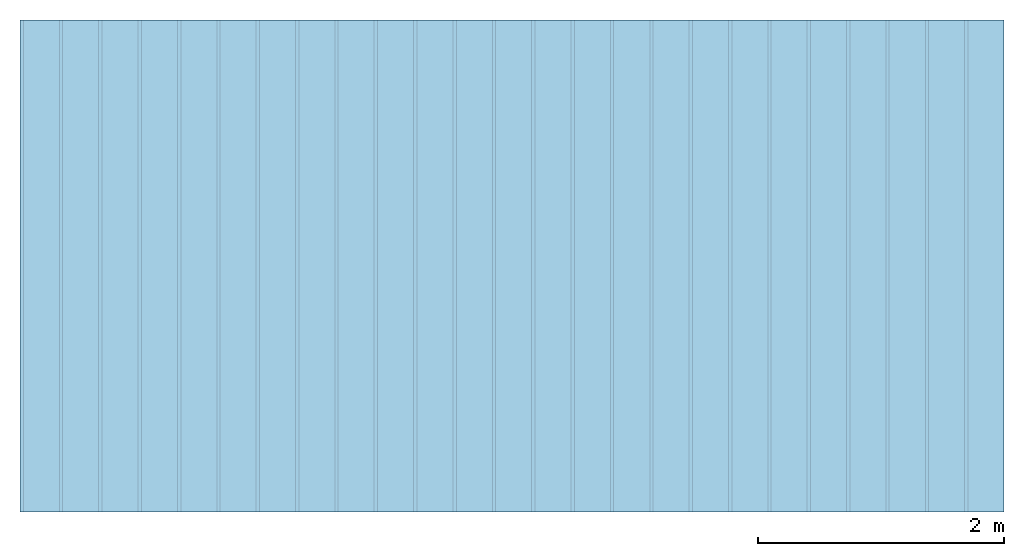
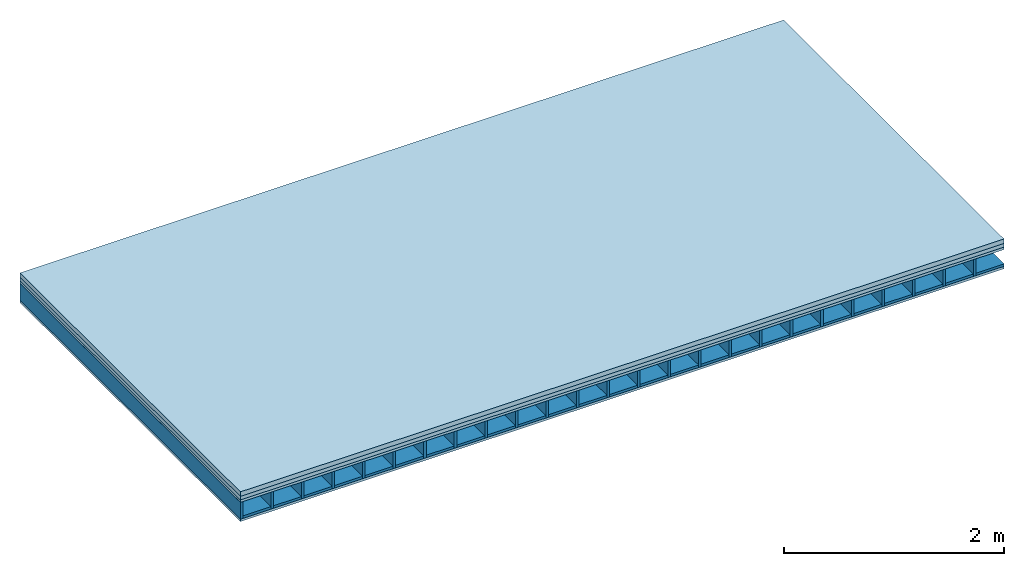
# One storey: 4 plates, 2 members, 1 element without a shape of its own.
"""IFC4 building model written with IfcOpenShell, lengths in metres."""

from ifc_helpers import new_model, si_unit, derived_unit, direction, frame, frame_2d, origin, origin_with_axes, place, context, project, spatial, rectangle, extrude, material, layer, layer_set, type_object, element, aggregate, save


model = new_model("IFC4")

# Units and contexts
plan_context = context("Plan", 3, precision=1e-05, world=origin(), true_north=direction((0.0, 1.0)))
model_context = context("Model", 3, precision=1e-05, world=origin(), true_north=direction((0.0, 1.0)))
ifc_project = project(units=[si_unit("LENGTHUNIT", "METRE"), derived_unit("SOUNDPRESSUREUNIT", [(si_unit("PRESSUREUNIT", "PASCAL", prefix="MICRO"), 0)]), si_unit("ENERGYUNIT", "JOULE", prefix="MEGA"), si_unit("MASSUNIT", "GRAM", prefix="KILO"), derived_unit("THERMALTRANSMITTANCEUNIT", [(si_unit("POWERUNIT", "WATT"), 1), (si_unit("AREAUNIT", "SQUARE_METRE"), -1), (si_unit("THERMODYNAMICTEMPERATUREUNIT", "KELVIN"), -1)]), derived_unit("AREADENSITYUNIT", [(si_unit("MASSUNIT", "GRAM", prefix="KILO"), 1), (si_unit("AREAUNIT", "SQUARE_METRE"), -1)]), derived_unit("USERDEFINED", [(si_unit("ENERGYUNIT", "JOULE", prefix="MEGA"), 1), (si_unit("AREAUNIT", "SQUARE_METRE"), -1)])], contexts=[plan_context, model_context])

# Site, building, storey
site = spatial("IfcSite", under=ifc_project)
building_placement = place(None, origin())
building = spatial("IfcBuilding", under=site, at=building_placement)
storey_placement = place(building_placement, origin())
storey = spatial("IfcBuildingStorey", under=building, at=storey_placement)

# Slab, members, plates
ifc_material_1 = material(Name="Concrete", Category="01.002")
ifc_layer_1 = layer(ifc_material_1, 0.05, Name="On-material")
ifc_material_2 = material(Name="ISOVER N 40")
ifc_layer_2 = layer(ifc_material_2, 0.04, Name="Impact sound insulation")
ifc_material_3 = material(Name="3-layer board Spruce Nova Top", Category="07.001")
ifc_layer_3 = layer(ifc_material_3, 0.027, Name="Sub-floor")
ifc_material_4 = material(Name="Rigid, of the art")
ifc_layer_4 = layer(ifc_material_4, 0.0, Name="Bond")
ifc_layer_5 = layer(None, 0.186, Name="Supporting structure")
ifc_layer_6 = layer(ifc_material_4, 0.0, Name="Bond")
ifc_layer_7 = layer(ifc_material_3, 0.027, Name="Lower layer 1")
ifc_layer_set = layer_set([ifc_layer_1, ifc_layer_2, ifc_layer_3, ifc_layer_4, ifc_layer_5, ifc_layer_6, ifc_layer_7])
slab_type = type_object("IfcSlabType", Name="A0017", PredefinedType="NOTDEFINED", material=ifc_layer_set)
slab_placement = place(None, frame((0.0, 0.0, 0.0), z_axis=(0.0, 0.0, -1.0), x_axis=(1.0, 0.0, 0.0)))
slab = element("IfcSlab", 1, at=slab_placement, inside=storey, type_object=slab_type, material=ifc_layer_set, Name="Slab #1")
ifc_material_5 = material()
member_1_placement = place(slab_placement, origin())
member_1 = element("IfcMember", 2, at=member_1_placement, material=ifc_material_5, Name="Supporting structure", context=plan_context, shape_type="SweptSolid", body=[
    extrude(rectangle(XDim=0.027, YDim=0.186, at=frame_2d((0.0135, 0.093), x_axis=(1.0, 0.0))), frame((0.0, 4.0, 0.117), z_axis=(0.0, -1.0, 0.0), x_axis=(1.0, 0.0, 0.0)), (0.0, 0.0, 1.0), 4.0),
    extrude(rectangle(XDim=0.027, YDim=0.186, at=frame_2d((0.0135, 0.093), x_axis=(1.0, 0.0))), frame((0.32, 4.0, 0.117), z_axis=(0.0, -1.0, 0.0), x_axis=(1.0, 0.0, 0.0)), (0.0, 0.0, 1.0), 4.0),
    extrude(rectangle(XDim=0.027, YDim=0.186, at=frame_2d((0.0135, 0.093), x_axis=(1.0, 0.0))), frame((0.64, 4.0, 0.117), z_axis=(0.0, -1.0, 0.0), x_axis=(1.0, 0.0, 0.0)), (0.0, 0.0, 1.0), 4.0),
    extrude(rectangle(XDim=0.027, YDim=0.186, at=frame_2d((0.0135, 0.093), x_axis=(1.0, 0.0))), frame((0.96, 4.0, 0.117), z_axis=(0.0, -1.0, 0.0), x_axis=(1.0, 0.0, 0.0)), (0.0, 0.0, 1.0), 4.0),
    extrude(rectangle(XDim=0.027, YDim=0.186, at=frame_2d((0.0135, 0.093), x_axis=(1.0, 0.0))), frame((1.28, 4.0, 0.117), z_axis=(0.0, -1.0, 0.0), x_axis=(1.0, 0.0, 0.0)), (0.0, 0.0, 1.0), 4.0),
    extrude(rectangle(XDim=0.027, YDim=0.186, at=frame_2d((0.0135, 0.093), x_axis=(1.0, 0.0))), frame((1.6, 4.0, 0.117), z_axis=(0.0, -1.0, 0.0), x_axis=(1.0, 0.0, 0.0)), (0.0, 0.0, 1.0), 4.0),
    extrude(rectangle(XDim=0.027, YDim=0.186, at=frame_2d((0.0135, 0.093), x_axis=(1.0, 0.0))), frame((1.92, 4.0, 0.117), z_axis=(0.0, -1.0, 0.0), x_axis=(1.0, 0.0, 0.0)), (0.0, 0.0, 1.0), 4.0),
    extrude(rectangle(XDim=0.027, YDim=0.186, at=frame_2d((0.0135, 0.093), x_axis=(1.0, 0.0))), frame((2.24, 4.0, 0.117), z_axis=(0.0, -1.0, 0.0), x_axis=(1.0, 0.0, 0.0)), (0.0, 0.0, 1.0), 4.0),
    extrude(rectangle(XDim=0.027, YDim=0.186, at=frame_2d((0.0135, 0.093), x_axis=(1.0, 0.0))), frame((2.56, 4.0, 0.117), z_axis=(0.0, -1.0, 0.0), x_axis=(1.0, 0.0, 0.0)), (0.0, 0.0, 1.0), 4.0),
    extrude(rectangle(XDim=0.027, YDim=0.186, at=frame_2d((0.0135, 0.093), x_axis=(1.0, 0.0))), frame((2.88, 4.0, 0.117), z_axis=(0.0, -1.0, 0.0), x_axis=(1.0, 0.0, 0.0)), (0.0, 0.0, 1.0), 4.0),
    extrude(rectangle(XDim=0.027, YDim=0.186, at=frame_2d((0.0135, 0.093), x_axis=(1.0, 0.0))), frame((3.2, 4.0, 0.117), z_axis=(0.0, -1.0, 0.0), x_axis=(1.0, 0.0, 0.0)), (0.0, 0.0, 1.0), 4.0),
    extrude(rectangle(XDim=0.027, YDim=0.186, at=frame_2d((0.0135, 0.093), x_axis=(1.0, 0.0))), frame((3.52, 4.0, 0.117), z_axis=(0.0, -1.0, 0.0), x_axis=(1.0, 0.0, 0.0)), (0.0, 0.0, 1.0), 4.0),
    extrude(rectangle(XDim=0.027, YDim=0.186, at=frame_2d((0.0135, 0.093), x_axis=(1.0, 0.0))), frame((3.84, 4.0, 0.117), z_axis=(0.0, -1.0, 0.0), x_axis=(1.0, 0.0, 0.0)), (0.0, 0.0, 1.0), 4.0),
    extrude(rectangle(XDim=0.027, YDim=0.186, at=frame_2d((0.0135, 0.093), x_axis=(1.0, 0.0))), frame((4.16, 4.0, 0.117), z_axis=(0.0, -1.0, 0.0), x_axis=(1.0, 0.0, 0.0)), (0.0, 0.0, 1.0), 4.0),
    extrude(rectangle(XDim=0.027, YDim=0.186, at=frame_2d((0.0135, 0.093), x_axis=(1.0, 0.0))), frame((4.48, 4.0, 0.117), z_axis=(0.0, -1.0, 0.0), x_axis=(1.0, 0.0, 0.0)), (0.0, 0.0, 1.0), 4.0),
    extrude(rectangle(XDim=0.027, YDim=0.186, at=frame_2d((0.0135, 0.093), x_axis=(1.0, 0.0))), frame((4.8, 4.0, 0.117), z_axis=(0.0, -1.0, 0.0), x_axis=(1.0, 0.0, 0.0)), (0.0, 0.0, 1.0), 4.0),
    extrude(rectangle(XDim=0.027, YDim=0.186, at=frame_2d((0.0135, 0.093), x_axis=(1.0, 0.0))), frame((5.12, 4.0, 0.117), z_axis=(0.0, -1.0, 0.0), x_axis=(1.0, 0.0, 0.0)), (0.0, 0.0, 1.0), 4.0),
    extrude(rectangle(XDim=0.027, YDim=0.186, at=frame_2d((0.0135, 0.093), x_axis=(1.0, 0.0))), frame((5.44, 4.0, 0.117), z_axis=(0.0, -1.0, 0.0), x_axis=(1.0, 0.0, 0.0)), (0.0, 0.0, 1.0), 4.0),
    extrude(rectangle(XDim=0.027, YDim=0.186, at=frame_2d((0.0135, 0.093), x_axis=(1.0, 0.0))), frame((5.76, 4.0, 0.117), z_axis=(0.0, -1.0, 0.0), x_axis=(1.0, 0.0, 0.0)), (0.0, 0.0, 1.0), 4.0),
    extrude(rectangle(XDim=0.027, YDim=0.186, at=frame_2d((0.0135, 0.093), x_axis=(1.0, 0.0))), frame((6.08, 4.0, 0.117), z_axis=(0.0, -1.0, 0.0), x_axis=(1.0, 0.0, 0.0)), (0.0, 0.0, 1.0), 4.0),
    extrude(rectangle(XDim=0.027, YDim=0.186, at=frame_2d((0.0135, 0.093), x_axis=(1.0, 0.0))), frame((6.4, 4.0, 0.117), z_axis=(0.0, -1.0, 0.0), x_axis=(1.0, 0.0, 0.0)), (0.0, 0.0, 1.0), 4.0),
    extrude(rectangle(XDim=0.027, YDim=0.186, at=frame_2d((0.0135, 0.093), x_axis=(1.0, 0.0))), frame((6.72, 4.0, 0.117), z_axis=(0.0, -1.0, 0.0), x_axis=(1.0, 0.0, 0.0)), (0.0, 0.0, 1.0), 4.0),
    extrude(rectangle(XDim=0.027, YDim=0.186, at=frame_2d((0.0135, 0.093), x_axis=(1.0, 0.0))), frame((7.04, 4.0, 0.117), z_axis=(0.0, -1.0, 0.0), x_axis=(1.0, 0.0, 0.0)), (0.0, 0.0, 1.0), 4.0),
    extrude(rectangle(XDim=0.027, YDim=0.186, at=frame_2d((0.0135, 0.093), x_axis=(1.0, 0.0))), frame((7.36, 4.0, 0.117), z_axis=(0.0, -1.0, 0.0), x_axis=(1.0, 0.0, 0.0)), (0.0, 0.0, 1.0), 4.0),
    extrude(rectangle(XDim=0.027, YDim=0.186, at=frame_2d((0.0135, 0.093), x_axis=(1.0, 0.0))), frame((7.68, 4.0, 0.117), z_axis=(0.0, -1.0, 0.0), x_axis=(1.0, 0.0, 0.0)), (0.0, 0.0, 1.0), 4.0),
])
ifc_material_6 = material(Name="Gravel of lime 3-6 mm")
member_2_placement = place(slab_placement, origin())
member_2 = element("IfcMember", 3, at=member_2_placement, material=ifc_material_6, Name="in supporting structure", context=plan_context, shape_type="SweptSolid", body=[
    extrude(rectangle(XDim=0.293, YDim=0.027, at=frame_2d((0.1465, 0.0135), x_axis=(1.0, 0.0))), frame((0.027, 4.0, 0.276), z_axis=(0.0, -1.0, 0.0), x_axis=(1.0, 0.0, 0.0)), (0.0, 0.0, 1.0), 4.0),
    extrude(rectangle(XDim=0.293, YDim=0.027, at=frame_2d((0.1465, 0.0135), x_axis=(1.0, 0.0))), frame((0.347, 4.0, 0.276), z_axis=(0.0, -1.0, 0.0), x_axis=(1.0, 0.0, 0.0)), (0.0, 0.0, 1.0), 4.0),
    extrude(rectangle(XDim=0.293, YDim=0.027, at=frame_2d((0.1465, 0.0135), x_axis=(1.0, 0.0))), frame((0.667, 4.0, 0.276), z_axis=(0.0, -1.0, 0.0), x_axis=(1.0, 0.0, 0.0)), (0.0, 0.0, 1.0), 4.0),
    extrude(rectangle(XDim=0.293, YDim=0.027, at=frame_2d((0.1465, 0.0135), x_axis=(1.0, 0.0))), frame((0.987, 4.0, 0.276), z_axis=(0.0, -1.0, 0.0), x_axis=(1.0, 0.0, 0.0)), (0.0, 0.0, 1.0), 4.0),
    extrude(rectangle(XDim=0.293, YDim=0.027, at=frame_2d((0.1465, 0.0135), x_axis=(1.0, 0.0))), frame((1.307, 4.0, 0.276), z_axis=(0.0, -1.0, 0.0), x_axis=(1.0, 0.0, 0.0)), (0.0, 0.0, 1.0), 4.0),
    extrude(rectangle(XDim=0.293, YDim=0.027, at=frame_2d((0.1465, 0.0135), x_axis=(1.0, 0.0))), frame((1.627, 4.0, 0.276), z_axis=(0.0, -1.0, 0.0), x_axis=(1.0, 0.0, 0.0)), (0.0, 0.0, 1.0), 4.0),
    extrude(rectangle(XDim=0.293, YDim=0.027, at=frame_2d((0.1465, 0.0135), x_axis=(1.0, 0.0))), frame((1.947, 4.0, 0.276), z_axis=(0.0, -1.0, 0.0), x_axis=(1.0, 0.0, 0.0)), (0.0, 0.0, 1.0), 4.0),
    extrude(rectangle(XDim=0.293, YDim=0.027, at=frame_2d((0.1465, 0.0135), x_axis=(1.0, 0.0))), frame((2.267, 4.0, 0.276), z_axis=(0.0, -1.0, 0.0), x_axis=(1.0, 0.0, 0.0)), (0.0, 0.0, 1.0), 4.0),
    extrude(rectangle(XDim=0.293, YDim=0.027, at=frame_2d((0.1465, 0.0135), x_axis=(1.0, 0.0))), frame((2.587, 4.0, 0.276), z_axis=(0.0, -1.0, 0.0), x_axis=(1.0, 0.0, 0.0)), (0.0, 0.0, 1.0), 4.0),
    extrude(rectangle(XDim=0.293, YDim=0.027, at=frame_2d((0.1465, 0.0135), x_axis=(1.0, 0.0))), frame((2.907, 4.0, 0.276), z_axis=(0.0, -1.0, 0.0), x_axis=(1.0, 0.0, 0.0)), (0.0, 0.0, 1.0), 4.0),
    extrude(rectangle(XDim=0.293, YDim=0.027, at=frame_2d((0.1465, 0.0135), x_axis=(1.0, 0.0))), frame((3.227, 4.0, 0.276), z_axis=(0.0, -1.0, 0.0), x_axis=(1.0, 0.0, 0.0)), (0.0, 0.0, 1.0), 4.0),
    extrude(rectangle(XDim=0.293, YDim=0.027, at=frame_2d((0.1465, 0.0135), x_axis=(1.0, 0.0))), frame((3.547, 4.0, 0.276), z_axis=(0.0, -1.0, 0.0), x_axis=(1.0, 0.0, 0.0)), (0.0, 0.0, 1.0), 4.0),
    extrude(rectangle(XDim=0.293, YDim=0.027, at=frame_2d((0.1465, 0.0135), x_axis=(1.0, 0.0))), frame((3.867, 4.0, 0.276), z_axis=(0.0, -1.0, 0.0), x_axis=(1.0, 0.0, 0.0)), (0.0, 0.0, 1.0), 4.0),
    extrude(rectangle(XDim=0.293, YDim=0.027, at=frame_2d((0.1465, 0.0135), x_axis=(1.0, 0.0))), frame((4.187, 4.0, 0.276), z_axis=(0.0, -1.0, 0.0), x_axis=(1.0, 0.0, 0.0)), (0.0, 0.0, 1.0), 4.0),
    extrude(rectangle(XDim=0.293, YDim=0.027, at=frame_2d((0.1465, 0.0135), x_axis=(1.0, 0.0))), frame((4.507, 4.0, 0.276), z_axis=(0.0, -1.0, 0.0), x_axis=(1.0, 0.0, 0.0)), (0.0, 0.0, 1.0), 4.0),
    extrude(rectangle(XDim=0.293, YDim=0.027, at=frame_2d((0.1465, 0.0135), x_axis=(1.0, 0.0))), frame((4.827, 4.0, 0.276), z_axis=(0.0, -1.0, 0.0), x_axis=(1.0, 0.0, 0.0)), (0.0, 0.0, 1.0), 4.0),
    extrude(rectangle(XDim=0.293, YDim=0.027, at=frame_2d((0.1465, 0.0135), x_axis=(1.0, 0.0))), frame((5.147, 4.0, 0.276), z_axis=(0.0, -1.0, 0.0), x_axis=(1.0, 0.0, 0.0)), (0.0, 0.0, 1.0), 4.0),
    extrude(rectangle(XDim=0.293, YDim=0.027, at=frame_2d((0.1465, 0.0135), x_axis=(1.0, 0.0))), frame((5.467, 4.0, 0.276), z_axis=(0.0, -1.0, 0.0), x_axis=(1.0, 0.0, 0.0)), (0.0, 0.0, 1.0), 4.0),
    extrude(rectangle(XDim=0.293, YDim=0.027, at=frame_2d((0.1465, 0.0135), x_axis=(1.0, 0.0))), frame((5.787, 4.0, 0.276), z_axis=(0.0, -1.0, 0.0), x_axis=(1.0, 0.0, 0.0)), (0.0, 0.0, 1.0), 4.0),
    extrude(rectangle(XDim=0.293, YDim=0.027, at=frame_2d((0.1465, 0.0135), x_axis=(1.0, 0.0))), frame((6.107, 4.0, 0.276), z_axis=(0.0, -1.0, 0.0), x_axis=(1.0, 0.0, 0.0)), (0.0, 0.0, 1.0), 4.0),
    extrude(rectangle(XDim=0.293, YDim=0.027, at=frame_2d((0.1465, 0.0135), x_axis=(1.0, 0.0))), frame((6.427, 4.0, 0.276), z_axis=(0.0, -1.0, 0.0), x_axis=(1.0, 0.0, 0.0)), (0.0, 0.0, 1.0), 4.0),
    extrude(rectangle(XDim=0.293, YDim=0.027, at=frame_2d((0.1465, 0.0135), x_axis=(1.0, 0.0))), frame((6.747, 4.0, 0.276), z_axis=(0.0, -1.0, 0.0), x_axis=(1.0, 0.0, 0.0)), (0.0, 0.0, 1.0), 4.0),
    extrude(rectangle(XDim=0.293, YDim=0.027, at=frame_2d((0.1465, 0.0135), x_axis=(1.0, 0.0))), frame((7.067, 4.0, 0.276), z_axis=(0.0, -1.0, 0.0), x_axis=(1.0, 0.0, 0.0)), (0.0, 0.0, 1.0), 4.0),
    extrude(rectangle(XDim=0.293, YDim=0.027, at=frame_2d((0.1465, 0.0135), x_axis=(1.0, 0.0))), frame((7.387, 4.0, 0.276), z_axis=(0.0, -1.0, 0.0), x_axis=(1.0, 0.0, 0.0)), (0.0, 0.0, 1.0), 4.0),
    extrude(rectangle(XDim=0.293, YDim=0.027, at=frame_2d((0.1465, 0.0135), x_axis=(1.0, 0.0))), frame((7.707, 4.0, 0.276), z_axis=(0.0, -1.0, 0.0), x_axis=(1.0, 0.0, 0.0)), (0.0, 0.0, 1.0), 4.0),
])
plate_1_placement = place(slab_placement, origin())
plate_1 = element("IfcPlate", 4, at=plate_1_placement, material=ifc_material_1, Name="On-material", context=plan_context, shape_type="SweptSolid", body=[
    extrude(rectangle(XDim=8.0, YDim=4.0, at=frame_2d((4.0, 2.0), x_axis=(1.0, 0.0))), origin_with_axes(), (0.0, 0.0, 1.0), 0.05),
])
plate_2_placement = place(slab_placement, origin())
plate_2 = element("IfcPlate", 5, at=plate_2_placement, material=ifc_material_2, Name="Impact sound insulation", context=plan_context, shape_type="SweptSolid", body=[
    extrude(rectangle(XDim=8.0, YDim=4.0, at=frame_2d((4.0, 2.0), x_axis=(1.0, 0.0))), frame((0.0, 0.0, 0.05), z_axis=(0.0, 0.0, 1.0), x_axis=(1.0, 0.0, 0.0)), (0.0, 0.0, 1.0), 0.04),
])
plate_3_placement = place(slab_placement, origin())
plate_3 = element("IfcPlate", 6, at=plate_3_placement, material=ifc_material_3, Name="Sub-floor", context=plan_context, shape_type="SweptSolid", body=[
    extrude(rectangle(XDim=8.0, YDim=4.0, at=frame_2d((4.0, 2.0), x_axis=(1.0, 0.0))), frame((0.0, 0.0, 0.09), z_axis=(0.0, 0.0, 1.0), x_axis=(1.0, 0.0, 0.0)), (0.0, 0.0, 1.0), 0.027),
])
plate_4_placement = place(slab_placement, origin())
plate_4 = element("IfcPlate", 7, at=plate_4_placement, material=ifc_material_3, Name="Lower layer 1", context=plan_context, shape_type="SweptSolid", body=[
    extrude(rectangle(XDim=8.0, YDim=4.0, at=frame_2d((4.0, 2.0), x_axis=(1.0, 0.0))), frame((0.0, 0.0, 0.303), z_axis=(0.0, 0.0, 1.0), x_axis=(1.0, 0.0, 0.0)), (0.0, 0.0, 1.0), 0.027),
])
aggregate(slab, [plate_1, plate_2, plate_3, member_1, member_2, plate_4])

save(model, "model.ifc")
